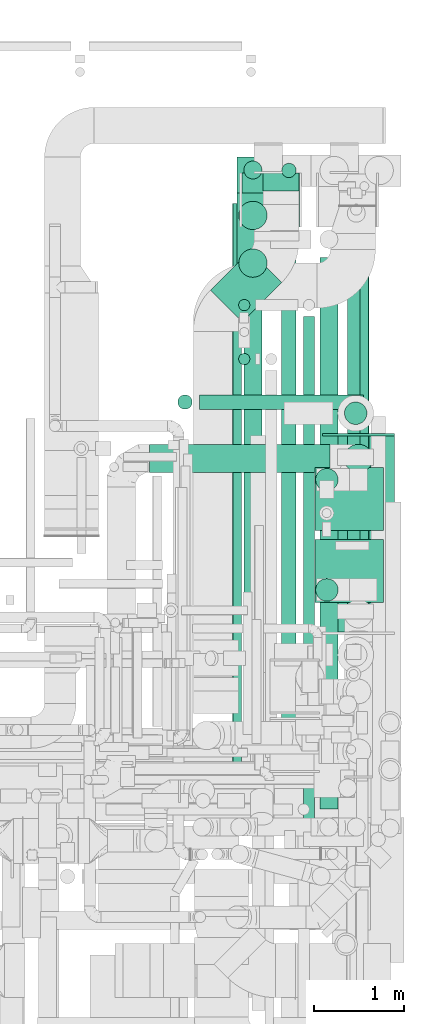
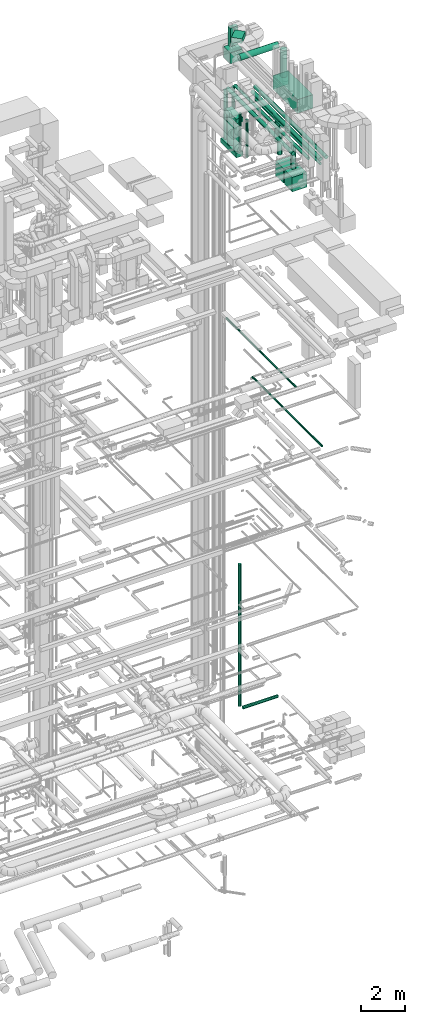
# One storey, part 83 of 337: 28 flow segments, 1 flow fitting.
"""IFC2X3 building model written with IfcOpenShell, lengths in millimetres."""

from ifc_helpers import new_model, entity, si_unit, converted_unit, derived_unit, direction, frame, origin, origin_2d_with_axis, place, context, subcontext, project, spatial, rectangle, circle, extrude, source, transform, mapped, material, type_object, type_shapes, element, save


model = new_model("IFC2X3")

# Units and contexts
model_context = context("Model", 3, precision=0.01, world=origin(), true_north=direction((6.12303176911189e-17, 1.0)))
body_context = subcontext(model_context, "Body", "Model", "MODEL_VIEW")
ifc_project = project(units=[si_unit("LENGTHUNIT", "METRE", prefix="MILLI"), si_unit("AREAUNIT", "SQUARE_METRE"), si_unit("VOLUMEUNIT", "CUBIC_METRE"), converted_unit("PLANEANGLEUNIT", "DEGREE", entity("IfcRatioMeasure", 0.0174532925199433), si_unit("PLANEANGLEUNIT", "RADIAN"), dimensions=[0, 0, 0, 0, 0, 0, 0]), si_unit("MASSUNIT", "GRAM", prefix="KILO"), derived_unit("MASSDENSITYUNIT", [(si_unit("MASSUNIT", "GRAM", prefix="KILO"), 1), (si_unit("LENGTHUNIT", "METRE"), -3)]), derived_unit("MOMENTOFINERTIAUNIT", [(si_unit("LENGTHUNIT", "METRE"), 4)]), si_unit("TIMEUNIT", "SECOND"), si_unit("FREQUENCYUNIT", "HERTZ"), si_unit("THERMODYNAMICTEMPERATUREUNIT", "DEGREE_CELSIUS"), derived_unit("THERMALTRANSMITTANCEUNIT", [(si_unit("MASSUNIT", "GRAM", prefix="KILO"), 1), (si_unit("THERMODYNAMICTEMPERATUREUNIT", "KELVIN"), -1), (si_unit("TIMEUNIT", "SECOND"), -3)]), derived_unit("VOLUMETRICFLOWRATEUNIT", [(si_unit("LENGTHUNIT", "METRE"), 3), (si_unit("TIMEUNIT", "SECOND"), -1)]), derived_unit("MASSFLOWRATEUNIT", [(si_unit("MASSUNIT", "GRAM", prefix="KILO"), 1), (si_unit("TIMEUNIT", "SECOND"), -1)]), derived_unit("ROTATIONALFREQUENCYUNIT", [(si_unit("TIMEUNIT", "SECOND"), -1)]), si_unit("ELECTRICCURRENTUNIT", "AMPERE"), si_unit("ELECTRICVOLTAGEUNIT", "VOLT"), si_unit("POWERUNIT", "WATT"), si_unit("FORCEUNIT", "NEWTON", prefix="KILO"), si_unit("ILLUMINANCEUNIT", "LUX"), si_unit("LUMINOUSFLUXUNIT", "LUMEN"), si_unit("LUMINOUSINTENSITYUNIT", "CANDELA"), derived_unit("USERDEFINED", [(si_unit("MASSUNIT", "GRAM", prefix="KILO"), -1), (si_unit("LENGTHUNIT", "METRE"), -2), (si_unit("TIMEUNIT", "SECOND"), 3), (si_unit("LUMINOUSFLUXUNIT", "LUMEN"), 1)]), derived_unit("LINEARVELOCITYUNIT", [(si_unit("LENGTHUNIT", "METRE"), 1), (si_unit("TIMEUNIT", "SECOND"), -1)]), si_unit("PRESSUREUNIT", "PASCAL"), derived_unit("USERDEFINED", [(si_unit("LENGTHUNIT", "METRE"), -2), (si_unit("MASSUNIT", "GRAM", prefix="KILO"), 1), (si_unit("TIMEUNIT", "SECOND"), -2)]), derived_unit("LINEARFORCEUNIT", [(si_unit("MASSUNIT", "GRAM", prefix="KILO"), 1), (si_unit("LENGTHUNIT", "METRE"), 1), (si_unit("TIMEUNIT", "SECOND"), -2), (si_unit("LENGTHUNIT", "METRE"), -1)]), derived_unit("PLANARFORCEUNIT", [(si_unit("MASSUNIT", "GRAM", prefix="KILO"), 1), (si_unit("LENGTHUNIT", "METRE"), 1), (si_unit("TIMEUNIT", "SECOND"), -2), (si_unit("LENGTHUNIT", "METRE"), -2)])], contexts=[model_context])

# Site, building, storey
site_placement = place(None, origin())
site = spatial("IfcSite", under=ifc_project, at=site_placement, CompositionType="ELEMENT")
building_placement = place(site_placement, origin())
building = spatial("IfcBuilding", under=site, at=building_placement, CompositionType="ELEMENT")
storey_placement = place(building_placement, origin())
storey = spatial("IfcBuildingStorey", under=building, at=storey_placement, CompositionType="ELEMENT", Elevation=0.0)

# Flow segments
duct_segment_type_1 = type_object("IfcDuctSegmentType", PredefinedType="NOTDEFINED")
flow_segment_1_placement = place(storey_placement, frame((71097.86, 14959.68, 35010.0)))
element("IfcFlowSegment", 1, at=flow_segment_1_placement, inside=storey, type_object=duct_segment_type_1, context=body_context, shape_type="SweptSolid", body=[
    extrude(rectangle(XDim=621.278997643705, YDim=500.000000000006, at=origin_2d_with_axis()), frame((396.43, 396.43, 0.0), z_axis=(0.0, 0.0, 1.0), x_axis=(0.707106781186561, 0.707106781186534, 0.0)), (0.0, 0.0, 1.0), 250.000000000004),
])
for number, where in (
    (2, (72260.47, 11845.08, 28450.0)),
    (3, (72260.47, 12645.08, 28450.0)),
):
    element("IfcFlowSegment", number, at=place(storey_placement, frame(where)), inside=storey, type_object=duct_segment_type_1, context=body_context, shape_type="SweptSolid", body=[
        extrude(rectangle(XDim=760.0, YDim=700.000000000001, at=origin_2d_with_axis()), frame((380.0, 350.0, 0.0)), (0.0, 0.0, 1.0), 800.0),
    ])
flow_segment_2_placement = place(storey_placement, frame((71395.11, 15390.94, 28475.0)))
element("IfcFlowSegment", 4, at=flow_segment_2_placement, inside=storey, type_object=duct_segment_type_1, context=body_context, shape_type="SweptSolid", body=[
    extrude(rectangle(XDim=1400.0, YDim=349.999999999998, at=origin_2d_with_axis()), frame((175.0, 700.0, 0.0), z_axis=(0.0, 0.0, 1.0), x_axis=(0.0, 1.0, 0.0)), (0.0, 0.0, 1.0), 250.000000000004),
])
flow_segment_3_placement = place(storey_placement, frame((71395.11, 15390.94, 30350.0)))
element("IfcFlowSegment", 5, at=flow_segment_3_placement, inside=storey, type_object=duct_segment_type_1, context=body_context, shape_type="SweptSolid", body=[
    extrude(rectangle(XDim=1000.0, YDim=349.999999999998, at=origin_2d_with_axis()), frame((175.0, 500.0, 0.0), z_axis=(0.0, 0.0, 1.0), x_axis=(0.0, 1.0, 0.0)), (0.0, 0.0, 1.0), 250.000000000004),
])
flow_segment_4_placement = place(storey_placement, frame((71447.1, 16013.61, 33250.0)))
element("IfcFlowSegment", 6, at=flow_segment_4_placement, inside=storey, type_object=duct_segment_type_1, context=body_context, shape_type="SweptSolid", body=[
    extrude(rectangle(XDim=640.000000000002, YDim=600.0, at=origin_2d_with_axis()), frame((320.0, 300.0, 0.0)), (0.0, 0.0, 1.0), 600.000000000002),
])
flow_segment_5_placement = place(storey_placement, frame((71681.11, 16413.61, 33870.0)))
element("IfcFlowSegment", 7, at=flow_segment_5_placement, inside=storey, type_object=duct_segment_type_1, context=body_context, shape_type="SweptSolid", body=[
    extrude(rectangle(XDim=200.000000000002, YDim=399.999999999996, at=origin_2d_with_axis()), frame((200.0, 100.0, 0.0), z_axis=(0.0, 0.0, 1.0), x_axis=(0.0, -1.0, 0.0)), (0.0, 0.0, 1.0), 1015.00000000001),
])
flow_segment_6_placement = place(storey_placement, frame((72343.11, 11515.31, 32946.26)))
element("IfcFlowSegment", 8, at=flow_segment_6_placement, inside=storey, type_object=duct_segment_type_1, context=body_context, shape_type="SweptSolid", body=[
    extrude(rectangle(XDim=2180.0, YDim=800.0, at=origin_2d_with_axis()), frame((400.0, 1090.0, 0.0), z_axis=(0.0, 0.0, 1.0), x_axis=(0.0, -1.0, 0.0)), (0.0, 0.0, 1.0), 750.000000000003),
])
duct_segment_type_2 = type_object("IfcDuctSegmentType", PredefinedType="NOTDEFINED")
flow_segment_7_placement = place(storey_placement, frame((70975.36, 13988.14, -881.6)))
element("IfcFlowSegment", 9, at=flow_segment_7_placement, inside=storey, type_object=duct_segment_type_2, context=body_context, shape_type="SweptSolid", body=[
    extrude(circle(Radius=80.0, at=origin_2d_with_axis()), frame((0.0, 81.6, 81.6), z_axis=(1.0, 0.0, 0.0), x_axis=(0.0, -1.0, 0.0)), (0.0, 0.0, 1.0), 1825.89258000008),
])
flow_segment_8_placement = place(storey_placement, frame((70733.76, 13988.14, -640.0)))
element("IfcFlowSegment", 10, at=flow_segment_8_placement, inside=storey, type_object=duct_segment_type_2, context=body_context, shape_type="SweptSolid", body=[
    extrude(circle(Radius=80.0, at=origin_2d_with_axis()), frame((81.6, 81.6, 0.0), z_axis=(0.0, 0.0, 1.0), x_axis=(0.0, 1.0, 0.0)), (0.0, 0.0, 1.0), 7805.00000000003),
])
flow_segment_9_placement = place(storey_placement, frame((72755.98, 10074.99, 15298.4)))
element("IfcFlowSegment", 11, at=flow_segment_9_placement, inside=storey, type_object=duct_segment_type_2, context=body_context, shape_type="SweptSolid", body=[
    extrude(circle(Radius=50.0, at=origin_2d_with_axis()), frame((51.6, 0.0, 51.6), z_axis=(0.0, 1.0, 0.0), x_axis=(1.0, 0.0, 0.0)), (0.0, 0.0, 1.0), 6293.58202000001),
])
flow_segment_10_placement = place(storey_placement, frame((71343.32, 9994.07, 19098.4)))
element("IfcFlowSegment", 12, at=flow_segment_10_placement, inside=storey, type_object=duct_segment_type_2, context=body_context, shape_type="SweptSolid", body=[
    extrude(circle(Radius=50.0, at=origin_2d_with_axis()), frame((51.6, 0.0, 51.6), z_axis=(0.0, 1.0, 0.0), x_axis=(1.0, 0.0, 0.0)), (0.0, 0.0, 1.0), 6280.00000000001),
])
flow_segment_11_placement = place(storey_placement, frame((72265.22, 13081.1, 29700.0)))
element("IfcFlowSegment", 13, at=flow_segment_11_placement, inside=storey, type_object=duct_segment_type_2, context=body_context, shape_type="SweptSolid", body=[
    extrude(circle(Radius=125.0, at=origin_2d_with_axis()), frame((126.6, 126.6, 0.0), z_axis=(0.0, 0.0, 1.0), x_axis=(0.0, -1.0, 0.0)), (0.0, 0.0, 1.0), 1250.00000000004),
])
flow_segment_12_placement = place(storey_placement, frame((70421.26, 13284.47, 35360.9)))
element("IfcFlowSegment", 14, at=flow_segment_12_placement, inside=storey, type_object=duct_segment_type_2, context=body_context, shape_type="SweptSolid", body=[
    extrude(circle(Radius=157.5, at=origin_2d_with_axis()), frame((0.0, 159.1, 159.1), z_axis=(1.0, 0.0, 0.0), x_axis=(0.0, -1.0, 0.0)), (0.0, 0.0, 1.0), 2006.84971203808),
])
flow_segment_13_placement = place(storey_placement, frame((72584.01, 13284.47, 33716.26)))
element("IfcFlowSegment", 15, at=flow_segment_13_placement, inside=storey, type_object=duct_segment_type_2, context=body_context, shape_type="SweptSolid", body=[
    extrude(circle(Radius=157.5, at=origin_2d_with_axis()), frame((159.1, 159.1, 0.0)), (0.0, 0.0, 1.0), 1488.7427546622),
])
flow_segment_14_placement = place(storey_placement, frame((72265.22, 11856.1, 29650.0)))
element("IfcFlowSegment", 16, at=flow_segment_14_placement, inside=storey, type_object=duct_segment_type_2, context=body_context, shape_type="SweptSolid", body=[
    extrude(circle(Radius=125.0, at=origin_2d_with_axis()), frame((126.6, 126.6, 0.0), z_axis=(0.0, 0.0, 1.0), x_axis=(0.0, -1.0, 0.0)), (0.0, 0.0, 1.0), 1300.14405402438),
])
flow_segment_15_placement = place(storey_placement, frame((72129.7, 9172.75, 31585.9)))
element("IfcFlowSegment", 17, at=flow_segment_15_placement, inside=storey, type_object=duct_segment_type_2, context=body_context, shape_type="SweptSolid", body=[
    extrude(circle(Radius=62.5, at=origin_2d_with_axis()), frame((64.1, 0.0, 64.1), z_axis=(0.0, 1.0, 0.0), x_axis=(1.0, 0.0, 0.0)), (0.0, 0.0, 1.0), 5850.00000000001),
])
flow_segment_16_placement = place(storey_placement, frame((72585.22, 13819.26, 29840.0)))
element("IfcFlowSegment", 18, at=flow_segment_16_placement, inside=storey, type_object=duct_segment_type_2, context=body_context, shape_type="SweptSolid", body=[
    extrude(circle(Radius=125.0, at=origin_2d_with_axis()), frame((126.6, 126.6, 0.0), z_axis=(0.0, 0.0, 1.0), x_axis=(0.0, -1.0, 0.0)), (0.0, 0.0, 1.0), 1110.00000000001),
])
flow_segment_17_placement = place(storey_placement, frame((72616.89, 9547.75, 31498.4)))
element("IfcFlowSegment", 19, at=flow_segment_17_placement, inside=storey, type_object=duct_segment_type_2, context=body_context, shape_type="SweptSolid", body=[
    extrude(circle(Radius=100.0, at=origin_2d_with_axis()), frame((101.6, 0.0, 101.6), z_axis=(0.0, 1.0, 0.0), x_axis=(1.0, 0.0, 0.0)), (0.0, 0.0, 1.0), 6420.00000000001),
])
flow_segment_18_placement = place(storey_placement, frame((71409.7, 15083.65, 29025.0)))
element("IfcFlowSegment", 20, at=flow_segment_18_placement, inside=storey, type_object=duct_segment_type_2, context=body_context, shape_type="SweptSolid", body=[
    extrude(circle(Radius=62.5, at=origin_2d_with_axis()), frame((64.1, 64.1, 0.0), z_axis=(0.0, 0.0, 1.0), x_axis=(0.0, -1.0, 0.0)), (0.0, 0.0, 1.0), 2050.00000000001),
])
flow_segment_19_placement = place(storey_placement, frame((71409.7, 14483.65, 29025.0)))
element("IfcFlowSegment", 21, at=flow_segment_19_placement, inside=storey, type_object=duct_segment_type_2, context=body_context, shape_type="SweptSolid", body=[
    extrude(circle(Radius=62.5, at=origin_2d_with_axis()), frame((64.1, 64.1, 0.0), z_axis=(0.0, 0.0, 1.0), x_axis=(-1.0, 0.0, 0.0)), (0.0, 0.0, 1.0), 2050.00000000002),
])
flow_segment_20_placement = place(storey_placement, frame((72312.2, 9547.75, 31498.4)))
element("IfcFlowSegment", 22, at=flow_segment_20_placement, inside=storey, type_object=duct_segment_type_2, context=body_context, shape_type="SweptSolid", body=[
    extrude(circle(Radius=100.0, at=origin_2d_with_axis()), frame((101.6, 0.0, 101.6), z_axis=(0.0, 1.0, 0.0), x_axis=(1.0, 0.0, 0.0)), (0.0, 0.0, 1.0), 6130.0),
])
flow_segment_21_placement = place(storey_placement, frame((71888.51, 16561.82, 28745.0)))
element("IfcFlowSegment", 23, at=flow_segment_21_placement, inside=storey, type_object=duct_segment_type_2, context=body_context, shape_type="SweptSolid", body=[
    extrude(circle(Radius=80.0, at=origin_2d_with_axis()), frame((81.6, 81.6, 0.0), z_axis=(0.0, 0.0, 1.0), x_axis=(-1.0, 0.0, 0.0)), (0.0, 0.0, 1.0), 2694.99999999988),
])
flow_segment_22_placement = place(storey_placement, frame((71468.51, 16546.82, 28745.0)))
element("IfcFlowSegment", 24, at=flow_segment_22_placement, inside=storey, type_object=duct_segment_type_2, context=body_context, shape_type="SweptSolid", body=[
    extrude(circle(Radius=100.0, at=origin_2d_with_axis()), frame((101.6, 101.6, 0.0)), (0.0, 0.0, 1.0), 2654.99999999996),
])
for number, where in (
    (25, (71411.01, 15984.32, 28745.0)),
    (26, (71411.01, 15454.32, 28745.0)),
):
    element("IfcFlowSegment", number, at=place(storey_placement, frame(where)), inside=storey, type_object=duct_segment_type_2, context=body_context, shape_type="SweptSolid", body=[
        extrude(circle(Radius=157.5, at=origin_2d_with_axis()), frame((159.1, 159.1, 0.0)), (0.0, 0.0, 1.0), 1584.99999999999),
    ])
flow_segment_23_placement = place(storey_placement, frame((71888.51, 9853.42, 31518.4)))
element("IfcFlowSegment", 27, at=flow_segment_23_placement, inside=storey, type_object=duct_segment_type_2, context=body_context, shape_type="SweptSolid", body=[
    extrude(circle(Radius=80.0, at=origin_2d_with_axis()), frame((81.6, 0.0, 81.6), z_axis=(0.0, 1.0, 0.0), x_axis=(-1.0, 0.0, 0.0)), (0.0, 0.0, 1.0), 6630.00000000002),
])
flow_segment_24_placement = place(storey_placement, frame((71468.51, 10548.42, 31498.4)))
element("IfcFlowSegment", 28, at=flow_segment_24_placement, inside=storey, type_object=duct_segment_type_2, context=body_context, shape_type="SweptSolid", body=[
    extrude(circle(Radius=100.0, at=origin_2d_with_axis()), frame((101.6, 0.0, 101.6), z_axis=(0.0, 1.0, 0.0), x_axis=(-1.0, 0.0, 0.0)), (0.0, 0.0, 1.0), 5900.00000000002),
])

# Flow fitting
ifc_material = material()
duct_fitting_type = type_object("IfcDuctFittingType", PredefinedType="NOTDEFINED", material=ifc_material)
shared_shape = source(origin(), body_context, "Body", "SweptSolid", [
    extrude(rectangle(XDim=24.9999999999999, YDim=800.0, at=origin_2d_with_axis()), frame((12.5, 0.0, -375.0)), (0.0, 0.0, 1.0), 750.0),
])
type_shapes(duct_fitting_type, [shared_shape])
flow_fitting_placement = place(storey_placement, frame((72743.11, 13695.31, 33321.26), z_axis=(0.0, 0.0, 1.0), x_axis=(0.0, 1.0, 0.0)))
element("IfcFlowFitting", 29, at=flow_fitting_placement, inside=storey, type_object=duct_fitting_type, material=ifc_material, context=body_context, shape_type="MappedRepresentation", body=[
    mapped(shared_shape, transform((0.0, 0.0, 0.0), scale=1.0)),
])

save(model, "model.ifc")
